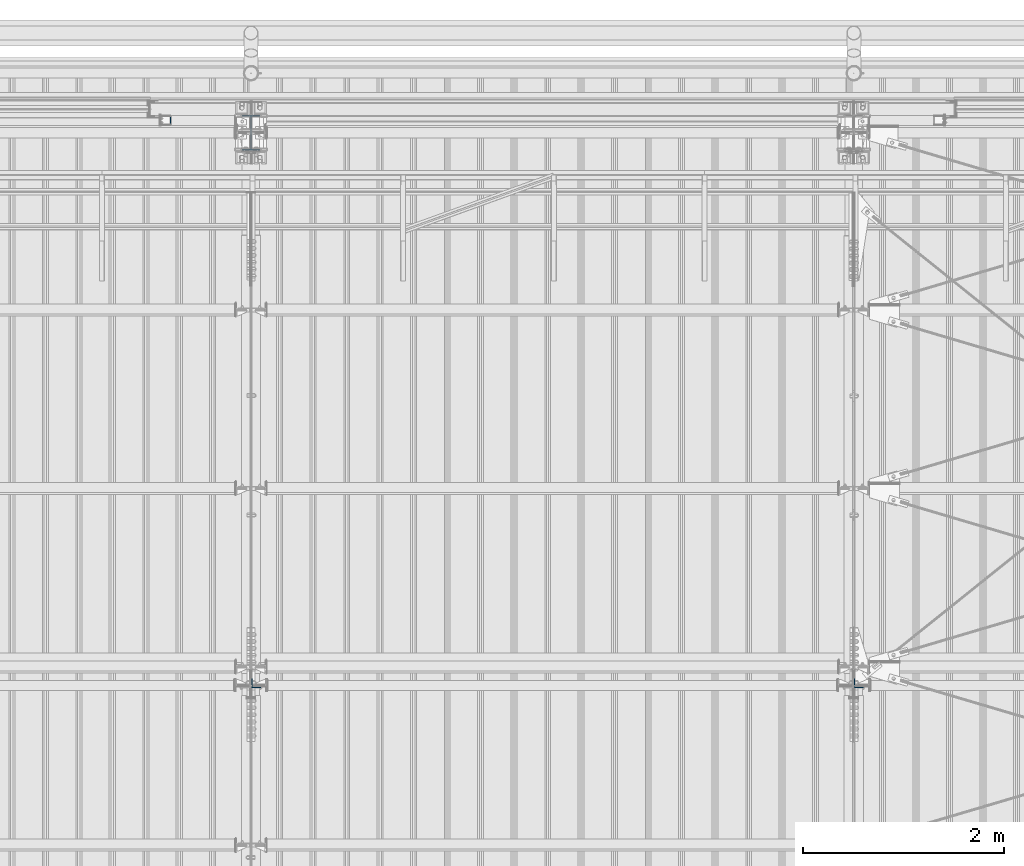
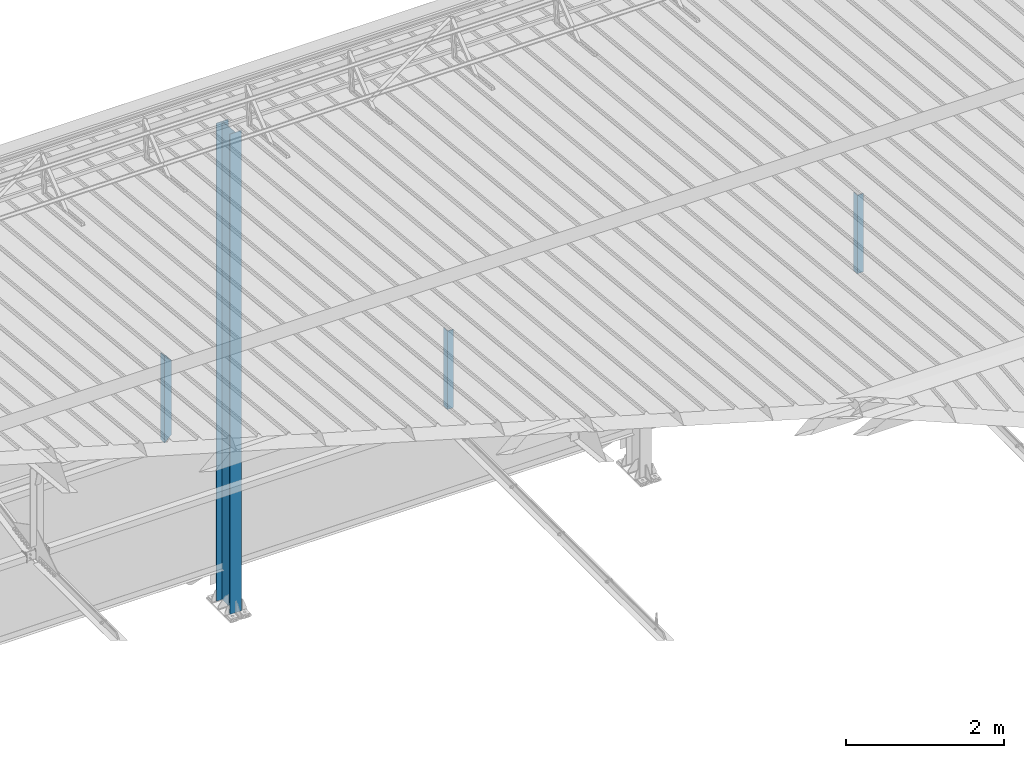
# One storey, part 237 of 709: 4 columns, 4 elements without a shape of their own.
"""IFC4 building model written with IfcOpenShell, lengths in millimetres."""

from ifc_helpers import new_model, si_unit, direction, frame, origin_with_axes, place, context, subcontext, project, spatial, polygons, material, element, aggregate, save


model = new_model("IFC4")

# Units and contexts
model_context = context("Model", 3, precision=0.2, world=origin_with_axes(), true_north=direction((0.0, 1.0)))
body_context = subcontext(model_context, "Body", "Model", "MODEL_VIEW")
ifc_project = project(units=[si_unit("LENGTHUNIT", "METRE", prefix="MILLI"), si_unit("AREAUNIT", "SQUARE_METRE"), si_unit("VOLUMEUNIT", "CUBIC_METRE"), si_unit("MASSUNIT", "GRAM", prefix="KILO"), si_unit("TIMEUNIT", "SECOND"), si_unit("PLANEANGLEUNIT", "RADIAN"), si_unit("SOLIDANGLEUNIT", "STERADIAN"), si_unit("THERMODYNAMICTEMPERATUREUNIT", "DEGREE_CELSIUS"), si_unit("LUMINOUSINTENSITYUNIT", "LUMEN")], contexts=[model_context])

# Site, building, storey
site_placement = place(None, origin_with_axes())
site = spatial("IfcSite", under=ifc_project, at=site_placement, CompositionType="ELEMENT")
building_placement = place(site_placement, origin_with_axes())
building = spatial("IfcBuilding", under=site, at=building_placement, Name="Undefined", CompositionType="ELEMENT")
storey_placement = place(building_placement, origin_with_axes())
storey = spatial("IfcBuildingStorey", under=building, at=storey_placement, Name="Undefined", CompositionType="ELEMENT", Elevation=0.0)

# Assembly, column
assembly_1_placement = place(storey_placement, frame((34000.0, 21827.0, -200.0), z_axis=(-1.0, 0.0, 0.0), x_axis=(0.0, 0.0, 1.0)))
assembly_1 = element("IfcElementAssembly", 1, at=assembly_1_placement, inside=storey)
ifc_material_1 = material(Name="C355-5", Category="STEEL")
column_1_placement = place(assembly_1_placement, origin_with_axes())
column_1 = element("IfcColumn", 2, at=column_1_placement, material=ifc_material_1, ObjectType="413", context=body_context, shape_type="Tessellation", body=[
    polygons([(25.0, -173.0, -87.0), (25.0, -164.0, -87.0), (7454.62297, -164.0, -87.0), (7455.52297, -173.0, -87.0), (25.0, -164.0, -3.0), (7454.62297, -164.0, -3.0), (25.0, 164.0, -3.0), (7421.82297, 164.0, -3.0), (25.0, 164.0, -87.0), (7421.82297, 164.0, -87.0), (25.0, 173.0, -87.0), (7420.92297, 173.0, -87.0), (25.0, 173.0, 87.0), (7420.92297, 173.0, 87.0), (25.0, 164.0, 87.0), (7421.82297, 164.0, 87.0), (25.0, 164.0, 3.0), (7421.82297, 164.0, 3.0), (25.0, -164.0, 3.0), (7454.62297, -164.0, 3.0), (25.0, -164.0, 87.0), (7454.62297, -164.0, 87.0), (25.0, -173.0, 87.0), (7455.52297, -173.0, 87.0)], [[[1, 2, 3, 4]], [[2, 5, 6, 3]], [[5, 7, 8, 6]], [[7, 9, 10, 8]], [[9, 11, 12, 10]], [[11, 13, 14, 12]], [[13, 15, 16, 14]], [[15, 17, 18, 16]], [[17, 19, 20, 18]], [[19, 21, 22, 20]], [[21, 23, 24, 22]], [[23, 1, 4, 24]], [[6, 8, 10, 12, 14, 16, 18, 20, 22, 24, 4, 3]], [[23, 21, 19, 17, 15, 13, 11, 9, 7, 5, 2, 1]]], closed=True),
])
aggregate(assembly_1, [column_1])

assembly_2_placement = place(storey_placement, frame((34051.0, 16347.7, 6024.30002), z_axis=(0.0, 1.0, 0.0), x_axis=(0.0, 0.0, 1.0)))
assembly_2 = element("IfcElementAssembly", 3, at=assembly_2_placement, inside=storey)
ifc_material_2 = material(Name="C345-5", Category="STEEL")
column_2_placement = place(assembly_2_placement, origin_with_axes())
column_2 = element("IfcColumn", 4, at=column_2_placement, material=ifc_material_2, ObjectType="436", context=body_context, shape_type="Tessellation", body=[
    polygons([(185.7, -45.0, -45.0), (185.7, 45.0, -45.0), (1399.4109, 45.0, -45.0), (1399.4109, -45.0, -45.0), (185.7, 45.0, -39.0), (1399.4109, 45.0, -39.0), (185.7, -39.0, -39.0), (1399.4109, -39.0, -39.0), (185.7, -39.0, 45.0), (1399.4109, -39.0, 45.0), (185.7, -45.0, 45.0), (1399.4109, -45.0, 45.0)], [[[1, 2, 3, 4]], [[2, 5, 6, 3]], [[5, 7, 8, 6]], [[7, 9, 10, 8]], [[9, 11, 12, 10]], [[11, 1, 4, 12]], [[6, 8, 10, 12, 4, 3]], [[11, 9, 7, 5, 2, 1]]], closed=True),
])
aggregate(assembly_2, [column_2])

assembly_3_placement = place(storey_placement, frame((40051.0, 16347.7, 6024.30002), z_axis=(0.0, 1.0, 0.0), x_axis=(0.0, 0.0, 1.0)))
assembly_3 = element("IfcElementAssembly", 5, at=assembly_3_placement, inside=storey)
column_3_placement = place(assembly_3_placement, origin_with_axes())
column_3 = element("IfcColumn", 6, at=column_3_placement, material=ifc_material_2, ObjectType="436", context=body_context, shape_type="Tessellation", body=[
    polygons([(185.7, -45.0, -45.0), (185.7, 45.0, -45.0), (1399.4109, 45.0, -45.0), (1399.4109, -45.0, -45.0), (185.7, 45.0, -39.0), (1399.4109, 45.0, -39.0), (185.7, -39.0, -39.0), (1399.4109, -39.0, -39.0), (185.7, -39.0, 45.0), (1399.4109, -39.0, 45.0), (185.7, -45.0, 45.0), (1399.4109, -45.0, 45.0)], [[[1, 2, 3, 4]], [[2, 5, 6, 3]], [[5, 7, 8, 6]], [[7, 9, 10, 8]], [[9, 11, 12, 10]], [[11, 1, 4, 12]], [[6, 8, 10, 12, 4, 3]], [[11, 9, 7, 5, 2, 1]]], closed=True),
])
aggregate(assembly_3, [column_3])

assembly_4_placement = place(storey_placement, frame((33150.0, 21950.0, 2600.0), z_axis=(-1.0, 0.0, 0.0), x_axis=(0.0, 0.0, 1.0)))
assembly_4 = element("IfcElementAssembly", 7, at=assembly_4_placement, inside=storey)
ifc_material_3 = material(Name="C355", Category="STEEL")
column_4_placement = place(assembly_4_placement, origin_with_axes())
column_4 = element("IfcColumn", 8, at=column_4_placement, material=ifc_material_3, ObjectType="493", context=body_context, shape_type="Tessellation", body=[
    polygons([(10.0, -50.0, 50.0), (110.0, -50.0, -50.0), (1260.0, -50.0, -50.0), (1360.0, -50.0, 50.0), (10.0, 50.0, 50.0), (1360.0, 50.0, 50.0), (110.0, 50.0, -50.0), (1260.0, 50.0, -50.0), (13.0, -47.0, 47.0), (13.0, 47.0, 47.0), (1357.0, 47.0, 47.0), (1357.0, -47.0, 47.0), (107.0, -47.0, -47.0), (1263.0, -47.0, -47.0), (107.0, 47.0, -47.0), (1263.0, 47.0, -47.0)], [[[1, 2, 3, 4]], [[5, 1, 4, 6]], [[7, 5, 6, 8]], [[2, 7, 8, 3]], [[1, 5, 7, 2], [9, 13, 15, 10]], [[9, 10, 11, 12]], [[13, 9, 12, 14]], [[15, 13, 14, 16]], [[10, 15, 16, 11]], [[3, 8, 6, 4], [14, 12, 11, 16]]], closed=True),
])
aggregate(assembly_4, [column_4])

save(model, "model.ifc")
